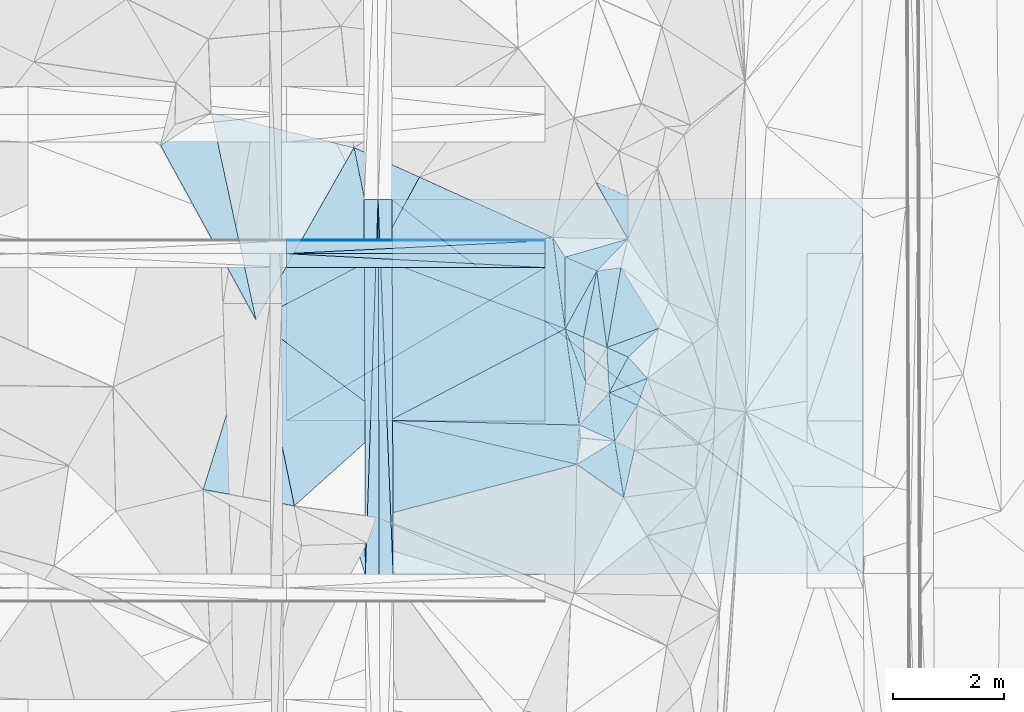
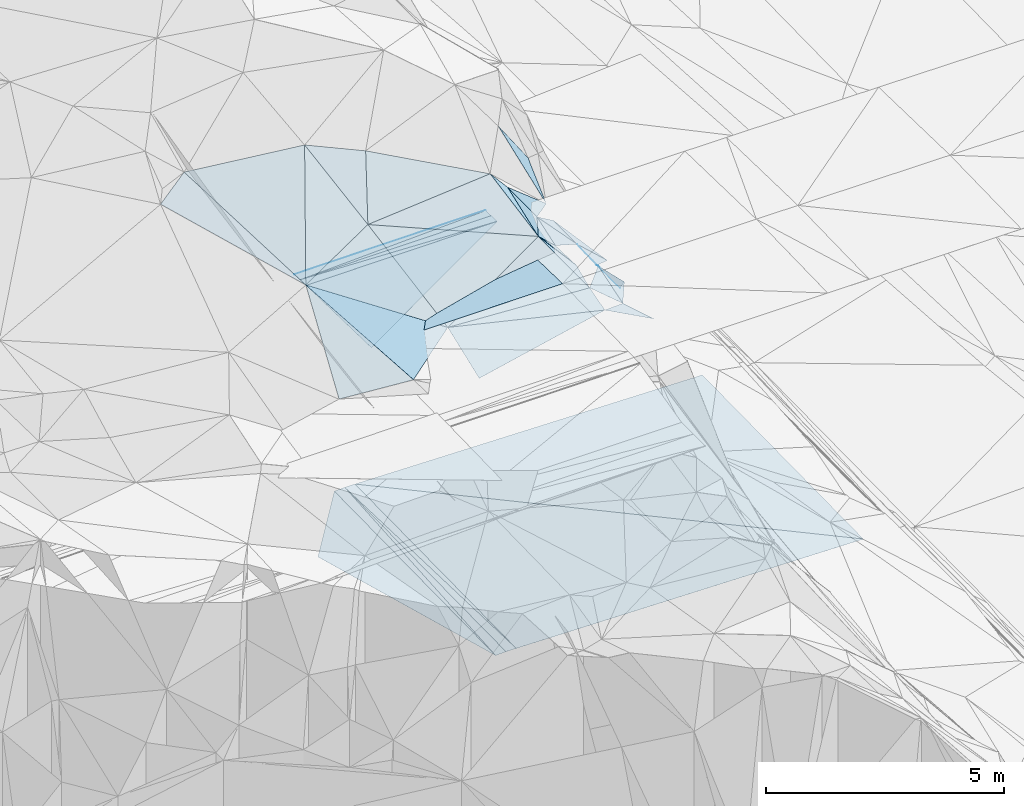
# One storey, part 62 of 275: 46 plates.
"""IFC2X3 building model written with IfcOpenShell, lengths in millimetres."""

import ifcopenshell
import ifcopenshell.guid

model = None  # the IFC model being written
_history = None  # IfcOwnerHistory: only IFC2X3 demands one
_inside = {}  # id of a spatial element -> (the spatial element, [elements in it])
_under = {}  # id of a project, library or spatial element -> (it, [spatial elements below it])
_declared = {}  # id of a project -> (the project, [libraries it declares])
_typed = {}  # id of a type object -> (the type object, [elements of that type])
_made_of = {}  # id of a material, layer set ... -> (it, [elements and type objects made of it])


def new_model(schema):
    """Start an empty IFC model of exactly this schema.

    Asked for "IFC4X3", IfcOpenShell would pick the latest addendum, in which some entities
    have other attributes; the version numbers below select the first issue.
    IFC2X3 requires an IfcOwnerHistory on every rooted entity: one is made here for all.
    """
    global model, _history
    if schema == "IFC4X3":
        model = ifcopenshell.file(schema_version=(4, 3, 0, 0))
    else:
        model = ifcopenshell.file(schema=schema)
    _inside.clear()
    _under.clear()
    _declared.clear()
    _typed.clear()
    _made_of.clear()
    _history = None
    if model.schema == "IFC2X3":
        org = make("IfcOrganization", Name="unknown")
        user = make(
            "IfcPersonAndOrganization",
            ThePerson=make("IfcPerson", FamilyName="unknown"),
            TheOrganization=org,
        )
        app = make(
            "IfcApplication",
            ApplicationDeveloper=org,
            Version="unknown",
            ApplicationFullName="unknown",
            ApplicationIdentifier="unknown",
        )
        _history = make(
            "IfcOwnerHistory",
            OwningUser=user,
            OwningApplication=app,
            ChangeAction="ADDED",
            CreationDate=0,
        )
    return model


def make(cls, **values):
    """One entity of the class cls with the attributes given. An attribute that is None is left unset."""
    return model.create_entity(
        cls, **{name: value for name, value in values.items() if value is not None}
    )


def rooted(cls, **values):
    """An entity with a GlobalId (a new one), such as an element, a storey or a relation."""
    return make(cls, GlobalId=ifcopenshell.guid.new(), OwnerHistory=_history, **values)


def si_unit(unit_type, name, prefix=None):
    """IfcSIUnit, for example si_unit("LENGTHUNIT", "METRE", prefix="MILLI")."""
    return make("IfcSIUnit", UnitType=unit_type, Prefix=prefix, Name=name)


def assignment(units):
    """IfcUnitAssignment: the units of a project."""
    return None if units is None else make("IfcUnitAssignment", Units=units)


def point(xyz):
    """IfcCartesianPoint."""
    return None if xyz is None else make("IfcCartesianPoint", Coordinates=xyz)


def direction(xyz):
    """IfcDirection."""
    return None if xyz is None else make("IfcDirection", DirectionRatios=xyz)


def frame(location, z_axis=None, x_axis=None):
    """IfcAxis2Placement3D, a coordinate frame: its origin and axes. An axis left out is left unset."""
    return make(
        "IfcAxis2Placement3D",
        Location=point(location),
        Axis=direction(z_axis),
        RefDirection=direction(x_axis),
    )


def origin_with_axes():
    """The frame at (0, 0, 0) with the z axis (0, 0, 1) and the x axis (1, 0, 0) written out."""
    return frame((0.0, 0.0, 0.0), z_axis=(0.0, 0.0, 1.0), x_axis=(1.0, 0.0, 0.0))


def place(relative_to, where):
    """IfcLocalPlacement: puts the frame where relative to a parent placement (None: the world)."""
    return make(
        "IfcLocalPlacement", PlacementRelTo=relative_to, RelativePlacement=where
    )


def context(
    kind, dimensions, precision=None, world=None, true_north=None, identifier=None
):
    """IfcGeometricRepresentationContext, for example the 3D "Model" context."""
    return make(
        "IfcGeometricRepresentationContext",
        ContextIdentifier=identifier,
        ContextType=kind,
        CoordinateSpaceDimension=dimensions,
        Precision=precision,
        WorldCoordinateSystem=world,
        TrueNorth=true_north,
    )


def subcontext(parent, identifier, kind, view, scale=None):
    """IfcGeometricRepresentationSubContext, for example "Body" below "Model"."""
    return make(
        "IfcGeometricRepresentationSubContext",
        ContextIdentifier=identifier,
        ContextType=kind,
        ParentContext=parent,
        TargetScale=scale,
        TargetView=view,
    )


def project(units=None, contexts=None):
    """IfcProject with its units and contexts."""
    return rooted(
        "IfcProject",
        Name="project",
        RepresentationContexts=contexts,
        UnitsInContext=assignment(units),
    )


def spatial(cls, under=None, at=None, **own):
    """A site, building, storey or space (cls), placed at a placement, below another one or the project."""
    s = rooted(cls, ObjectPlacement=at, **own)
    if under is not None:
        _under.setdefault(under.id(), (under, []))[1].append(s)
    return s


def polyline(points):
    """IfcPolyline through the points."""
    return make("IfcPolyline", Points=[point(p) for p in points])


def outline(outer, holes=None, kind="AREA"):
    """IfcArbitraryClosedProfileDef: a profile drawn as a closed curve; with holes, ...WithVoids."""
    if holes is None:
        return make("IfcArbitraryClosedProfileDef", ProfileType=kind, OuterCurve=outer)
    return make(
        "IfcArbitraryProfileDefWithVoids",
        ProfileType=kind,
        OuterCurve=outer,
        InnerCurves=holes,
    )


def extrude(swept, where, along, depth):
    """IfcExtrudedAreaSolid: the profile swept, set in the frame where, extruded along a direction by depth."""
    return make(
        "IfcExtrudedAreaSolid",
        SweptArea=swept,
        Position=where,
        ExtrudedDirection=direction(along),
        Depth=depth,
    )


def shape(context_of_items, identifier, shape_type, items):
    """IfcShapeRepresentation: the items that make up one representation, for example the "Body"."""
    return make(
        "IfcShapeRepresentation",
        ContextOfItems=context_of_items,
        RepresentationIdentifier=identifier,
        RepresentationType=shape_type,
        Items=items,
    )


def material(Name=None, Category=None):
    """IfcMaterial."""
    return make("IfcMaterial", Name=Name, Category=Category)


def made_of(thing, what):
    """Note that an element or type object is made of a material, layer set ...; save() writes the relation."""
    if what is not None:
        _made_of.setdefault(what.id(), (what, []))[1].append(thing)
    return thing


def type_object(cls, material=None, **own):
    """A type object (cls), such as IfcWallType, which elements share."""
    return made_of(rooted(cls, **own), material)


def element(
    cls,
    number,
    at=None,
    inside=None,
    cuts=None,
    type_object=None,
    material=None,
    context=None,
    identifier="Body",
    shape_type=None,
    held_by="IfcProductDefinitionShape",
    body=None,
    shapes=None,
    **own,
):
    """One element of the class cls, such as IfcWall. Its Tag is "e" and its number.

    at: its placement. inside: the storey or other place that contains it. cuts: it is an
    opening in that element (IfcRelVoidsElement). A single representation is given by context,
    identifier, shape_type and body (its items); several are given by shapes. held_by: the class
    of the entity that holds the representations. save() writes the other relations.
    """
    e = rooted(cls, Tag="e%d" % number, ObjectPlacement=at, **own)
    if body is not None:
        shapes = [shape(context, identifier, shape_type, body)]
    if shapes is not None:
        e.Representation = make(held_by, Representations=shapes)
    if inside is not None:
        _inside.setdefault(inside.id(), (inside, []))[1].append(e)
    if cuts is not None:
        rooted(
            "IfcRelVoidsElement", RelatingBuildingElement=cuts, RelatedOpeningElement=e
        )
    if type_object is not None:
        _typed.setdefault(type_object.id(), (type_object, []))[1].append(e)
    return made_of(e, material)


def aggregate(whole, parts):
    """IfcRelAggregates: a whole, such as a stair, and the parts it consists of."""
    return rooted("IfcRelAggregates", RelatingObject=whole, RelatedObjects=parts)


def save(model, path):
    """Write the relations noted so far, then the file.

    IfcRelAggregates (storeys below a building ...), IfcRelContainedInSpatialStructure (elements
    in a storey), IfcRelDefinesByType, IfcRelAssociatesMaterial and IfcRelDeclares: one each for
    every whole, place, type object, material and project.
    """
    for whole, parts in _under.values():
        aggregate(whole, parts)
    for where, things in _inside.values():
        rooted(
            "IfcRelContainedInSpatialStructure",
            RelatedElements=things,
            RelatingStructure=where,
        )
    for kind, things in _typed.values():
        rooted("IfcRelDefinesByType", RelatedObjects=things, RelatingType=kind)
    for what, things in _made_of.values():
        rooted("IfcRelAssociatesMaterial", RelatedObjects=things, RelatingMaterial=what)
    for by, libraries in _declared.values():
        rooted("IfcRelDeclares", RelatingContext=by, RelatedDefinitions=libraries)
    model.write(path)


model = new_model("IFC2X3")

# Units and contexts
model_context = context("Model", 3, precision=1e-05, world=origin_with_axes())
body_context = subcontext(model_context, "Body", "Model", "MODEL_VIEW")
ifc_project = project(units=[si_unit("LENGTHUNIT", "METRE", prefix="MILLI"), si_unit("AREAUNIT", "SQUARE_METRE"), si_unit("VOLUMEUNIT", "CUBIC_METRE"), si_unit("MASSUNIT", "GRAM", prefix="KILO"), si_unit("TIMEUNIT", "SECOND"), si_unit("PLANEANGLEUNIT", "RADIAN"), si_unit("SOLIDANGLEUNIT", "STERADIAN"), si_unit("THERMODYNAMICTEMPERATUREUNIT", "DEGREE_CELSIUS"), si_unit("LUMINOUSINTENSITYUNIT", "LUMEN")], contexts=[model_context])

# Site, building, storey
site_placement = place(None, origin_with_axes())
site = spatial("IfcSite", under=ifc_project, at=site_placement, CompositionType="ELEMENT")
building_placement = place(site_placement, origin_with_axes())
building = spatial("IfcBuilding", under=site, at=building_placement, Name="Undefined", CompositionType="ELEMENT")
storey_placement = place(building_placement, origin_with_axes())
storey = spatial("IfcBuildingStorey", under=building, at=storey_placement, Name="Undefined", CompositionType="ELEMENT", Elevation=0.0)

# Plates
ifc_material = material()
plate_type_1 = type_object("IfcPlateType", PredefinedType="NOTDEFINED")
plate_1_placement = place(storey_placement, frame((-105469.201324348, 63292.9219473993, 49162.3171549473), z_axis=(0.00445671719350375, -0.0249921977119847, -0.99967771192789), x_axis=(0.860197157792345, 0.509883731909383, -0.00891233191333803)))
element("IfcPlate", 1, at=plate_1_placement, inside=storey, type_object=plate_type_1, material=ifc_material, Name="00_PR", context=body_context, shape_type="SweptSolid", body=[
    extrude(outline(polyline([(0.0, 0.0), (5392.86474609375, 2.29192664846778e-08), (3989.93603515625, 2366.22436523438), (0.0, 0.0)])), frame((-8.85201319254618e-08, 2.18876761149539e-07, -0.5000001331573), z_axis=(0.0, 0.0, 1.0), x_axis=(1.0, 0.0, 0.0)), (0.0, 0.0, 1.0), 1.0),
])
plate_2_placement = place(storey_placement, frame((-105469.043765166, 66042.921967373, 49093.5671550756), z_axis=(0.00445671719350375, -0.0249921977119847, -0.99967771192789), x_axis=(0.999990054538811, -5.7357974325105e-05, 0.00445954409423353)))
element("IfcPlate", 2, at=plate_2_placement, inside=storey, type_object=plate_type_1, material=ifc_material, Name="00_PR", context=body_context, shape_type="SweptSolid", body=[
    extrude(outline(polyline([(0.0, 0.0), (4638.8154296875, -1.62399373948574e-08), (0.306771844625473, 2750.85913085938), (0.0, 0.0)])), frame((-8.85201319254618e-08, 2.18876761149539e-07, -0.5000001331573), z_axis=(0.0, 0.0, 1.0), x_axis=(1.0, 0.0, 0.0)), (0.0, 0.0, 1.0), 1.0),
])
plate_type_2 = type_object("IfcPlateType", PredefinedType="NOTDEFINED")
plate_3_placement = place(storey_placement, frame((-103826.650499123, 67263.1940728969, 42600.7227228708), z_axis=(0.0498540514075518, 0.0199905378181606, -0.998556434036652), x_axis=(0.00314771709881759, -0.999797850718584, -0.019858236970227)))
element("IfcPlate", 3, at=plate_3_placement, inside=storey, type_object=plate_type_2, material=ifc_material, Name="00_PR", context=body_context, shape_type="SweptSolid", body=[
    extrude(outline(polyline([(0.0, 0.0), (6745.06005859375, -3.5739503800869e-08), (6745.44873046875, 250.311813354492), (0.0, 0.0)])), frame((-8.85201319254618e-08, 2.18876761149539e-07, -0.5000001331573), z_axis=(0.0, 0.0, 1.0), x_axis=(1.0, 0.0, 0.0)), (0.0, 0.0, 1.0), 1.0),
])
plate_4_placement = place(storey_placement, frame((-104076.649661737, 67262.5461842943, 42588.2227234709), z_axis=(0.049876128343471, 0.0199897647867783, -0.998555347051547), x_axis=(0.998748985088213, 0.00258831910303945, 0.0499376149759477)))
element("IfcPlate", 4, at=plate_4_placement, inside=storey, type_object=plate_type_2, material=ifc_material, Name="00_PR", context=body_context, shape_type="SweptSolid", body=[
    extrude(outline(polyline([(0.0, 0.0), (250.312271118164, 1.46246748045087e-09), (-2.93840003013611, 6745.3388671875), (0.0, 0.0)])), frame((-8.85201319254618e-08, 2.18876761149539e-07, -0.5000001331573), z_axis=(0.0, 0.0, 1.0), x_axis=(1.0, 0.0, 0.0)), (0.0, 0.0, 1.0), 1.0),
])
plate_5_placement = place(storey_placement, frame((-103555.455830525, 60520.4247199042, 42461.777200013), z_axis=(-0.0200656186730238, 0.0197911885320088, -0.999602761002469), x_axis=(-0.999793181742788, -0.00370851510160745, 0.0199960160125457)))
element("IfcPlate", 5, at=plate_5_placement, inside=storey, type_object=plate_type_2, material=ifc_material, Name="00_PR", context=body_context, shape_type="SweptSolid", body=[
    extrude(outline(polyline([(0.0, 0.0), (250.0498046875, 2.5465851649642e-10), (248.946228027344, 6745.06005859375), (0.0, 0.0)])), frame((-8.85201319254618e-08, 2.18876761149539e-07, -0.5000001331573), z_axis=(0.0, 0.0, 1.0), x_axis=(1.0, 0.0, 0.0)), (0.0, 0.0, 1.0), 1.0),
])
plate_6_placement = place(storey_placement, frame((-103826.685452077, 67263.1939715177, 42600.7221993988), z_axis=(-0.0200433175559558, 0.0197920939151684, -0.999603190491009), x_axis=(0.999796712713563, 0.00258737511018379, -0.0199959680233973)))
element("IfcPlate", 6, at=plate_6_placement, inside=storey, type_object=plate_type_2, material=ifc_material, Name="00_PR", context=body_context, shape_type="SweptSolid", body=[
    extrude(outline(polyline([(0.0, 0.0), (250.050399780273, 6.83940015733242e-10), (256.506774902344, 6744.77685546875), (0.0, 0.0)])), frame((-8.85201319254618e-08, 2.18876761149539e-07, -0.5000001331573), z_axis=(0.0, 0.0, 1.0), x_axis=(1.0, 0.0, 0.0)), (0.0, 0.0, 1.0), 1.0),
])
for number, where, z_axis, x_axis, name in (
    (7, (-100830.274498399, 66042.6558914657, 49114.2541558087), (0.00445671719350375, -0.0249921977119847, -0.99967771192789), (-0.999990054538875, 5.7357962472799e-05, -0.00445954408009802), "00_PR"),
    (8, (-105469.029439759, 66292.9219611694, 49087.3171556949), (0.00445671719350375, -0.0249921977119847, -0.99967771192789), (0.999990054538811, -5.7357974325105e-05, 0.00445954409423353), "00_PR"),
):
    element("IfcPlate", number, at=place(storey_placement, frame(where, z_axis=z_axis, x_axis=x_axis)), inside=storey, type_object=plate_type_2, material=ifc_material, Name=name, context=body_context, shape_type="SweptSolid", body=[
        extrude(outline(polyline([(0.0, 0.0), (4638.8154296875, -1.62399373948574e-08), (4638.84326171875, 250.078109741211), (0.0, 0.0)])), frame((-8.85201319254618e-08, 2.18876761149539e-07, -0.5000001331573), z_axis=(0.0, 0.0, 1.0), x_axis=(1.0, 0.0, 0.0)), (0.0, 0.0, 1.0), 1.0),
    ])
plate_type_3 = type_object("IfcPlateType", PredefinedType="NOTDEFINED")
plate_7_placement = place(storey_placement, frame((-100830.245854265, 66542.6433940911, 49095.5046256384), z_axis=(0.00445131648355445, -0.0499887354570713, -0.998739862080695), x_axis=(-7.45929924247194e-05, -0.998749770672438, 0.0499888989440421)))
element("IfcPlate", 9, at=plate_7_placement, inside=storey, type_object=plate_type_3, material=ifc_material, Name="00_PR", context=body_context, shape_type="SweptSolid", body=[
    extrude(outline(polyline([(0.0, 0.0), (20.0244464874268, -2.91038304567337e-11), (19.0705547332764, 4638.8154296875), (0.0, 0.0)])), frame((-8.85201319254618e-08, 2.18876761149539e-07, -0.5000001331573), z_axis=(0.0, 0.0, 1.0), x_axis=(1.0, 0.0, 0.0)), (0.0, 0.0, 1.0), 1.0),
])
plate_8_placement = place(storey_placement, frame((-105469.0166185, 66522.9100808625, 49075.8176243944), z_axis=(0.00445111480713597, -0.0499389231699433, -0.998742354929238), x_axis=(7.46349675932083e-05, 0.998752262639191, -0.0499390859219244)))
element("IfcPlate", 10, at=plate_8_placement, inside=storey, type_object=plate_type_3, material=ifc_material, Name="00_PR", context=body_context, shape_type="SweptSolid", body=[
    extrude(outline(polyline([(0.0, 0.0), (20.0243949890137, 1.30967237055302e-10), (19.0717754364014, 4638.8154296875), (0.0, 0.0)])), frame((-8.85201319254618e-08, 2.18876761149539e-07, -0.5000001331573), z_axis=(0.0, 0.0, 1.0), x_axis=(1.0, 0.0, 0.0)), (0.0, 0.0, 1.0), 1.0),
])
plate_type_4 = type_object("IfcPlateType", PredefinedType="NOTDEFINED")
plate_9_placement = place(storey_placement, frame((-106016.675215743, 65102.2080277684, 49869.5147014846), z_axis=(0.00436078686112087, 0.240791988652599, -0.970566948612345), x_axis=(-0.468948656068637, 0.857727687735567, 0.210690226786193)))
element("IfcPlate", 11, at=plate_9_placement, inside=storey, type_object=plate_type_4, material=ifc_material, Name="00", context=body_context, shape_type="SweptSolid", body=[
    extrude(outline(polyline([(0.0, 0.0), (3654.65454101563, 4.97675500810146e-09), (3764.02197265625, 1088.27331542969), (0.0, 0.0)])), frame((-8.85201319254618e-08, 2.18876761149539e-07, -0.5000001331573), z_axis=(0.0, 0.0, 1.0), x_axis=(1.0, 0.0, 0.0)), (0.0, 0.0, 1.0), 1.0),
])
plate_type_5 = type_object("IfcPlateType", PredefinedType="NOTDEFINED")
plate_10_placement = place(storey_placement, frame((-100830.24734789, 66522.6440090119, 49096.5056244012), z_axis=(0.00445111678322818, -0.0499329100893918, -0.998742655567182), x_axis=(-5.57119462018614e-05, -0.998752560311599, 0.0499331569921673)))
element("IfcPlate", 12, at=plate_10_placement, inside=storey, type_object=plate_type_5, material=ifc_material, Name="00_PR", context=body_context, shape_type="SweptSolid", body=[
    extrude(outline(polyline([(0.0, 0.0), (230.287857055664, 7.71251507103443e-10), (229.247589111328, 4638.8154296875), (0.0, 0.0)])), frame((-8.85201319254618e-08, 2.18876761149539e-07, -0.5000001331573), z_axis=(0.0, 0.0, 1.0), x_axis=(1.0, 0.0, 0.0)), (0.0, 0.0, 1.0), 1.0),
])
plate_11_placement = place(storey_placement, frame((-105469.029446194, 66292.9094898988, 49087.3176237522), z_axis=(0.00445133086710392, -0.0499372419707403, -0.998742438027877), x_axis=(5.57099558727869e-05, 0.998752343723243, -0.049937488961006)))
element("IfcPlate", 13, at=plate_11_placement, inside=storey, type_object=plate_type_5, material=ifc_material, Name="00_PR", context=body_context, shape_type="SweptSolid", body=[
    extrude(outline(polyline([(0.0, 0.0), (230.28791809082, 9.89530235528946e-10), (229.247482299805, 4638.8154296875), (0.0, 0.0)])), frame((-8.85201319254618e-08, 2.18876761149539e-07, -0.5000001331573), z_axis=(0.0, 0.0, 1.0), x_axis=(1.0, 0.0, 0.0)), (0.0, 0.0, 1.0), 1.0),
])
plate_type_6 = type_object("IfcPlateType", PredefinedType="NOTDEFINED")
plate_12_placement = place(storey_placement, frame((-105551.565501963, 65398.0618447015, 42551.3640996621), z_axis=(-0.0001170259226823, 0.0198571444894536, -0.999802820618975), x_axis=(0.620328597982233, 0.784188824147713, 0.0155022129783304)))
element("IfcPlate", 14, at=plate_12_placement, inside=storey, type_object=plate_type_6, material=ifc_material, Name="00_PR", context=body_context, shape_type="SweptSolid", body=[
    extrude(outline(polyline([(0.0, 0.0), (2377.59619140625, 1.44063960760832e-09), (-2899.85986328125, 4200.9599609375), (0.0, 0.0)])), frame((-8.85201319254618e-08, 2.18876761149539e-07, -0.5000001331573), z_axis=(0.0, 0.0, 1.0), x_axis=(1.0, 0.0, 0.0)), (0.0, 0.0, 1.0), 1.0),
])
plate_type_7 = type_object("IfcPlateType", PredefinedType="NOTDEFINED")
plate_13_placement = place(storey_placement, frame((-103576.685878312, 67263.8409619394, 42595.7221990522), z_axis=(-0.0200455022387264, 0.0198206835130344, -0.999602580201289), x_axis=(0.99979662068917, 0.00260989112805105, -0.0199976430315116)))
element("IfcPlate", 15, at=plate_13_placement, inside=storey, type_object=plate_type_7, material=ifc_material, Name="00_PR", context=body_context, shape_type="SweptSolid", body=[
    extrude(outline(polyline([(0.0, 0.0), (8442.9951171875, -4.58239810541272e-08), (8449.439453125, 6735.3330078125), (0.0, 0.0)])), frame((-8.85201319254618e-08, 2.18876761149539e-07, -0.5000001331573), z_axis=(0.0, 0.0, 1.0), x_axis=(1.0, 0.0, 0.0)), (0.0, 0.0, 1.0), 1.0),
])
plate_type_8 = type_object("IfcPlateType", PredefinedType="NOTDEFINED")
plate_14_placement = place(storey_placement, frame((-95114.0626632694, 60551.9062880618, 42292.9291988022), z_axis=(-0.0200682510399799, 0.0197920061024449, -0.999602691970483), x_axis=(-0.999793062227786, -0.0037286561281597, 0.0199982460397029)))
element("IfcPlate", 16, at=plate_14_placement, inside=storey, type_object=plate_type_8, material=ifc_material, Name="00_PR", context=body_context, shape_type="SweptSolid", body=[
    extrude(outline(polyline([(0.0, 0.0), (8443.140625, -1.06010702438653e-08), (8441.900390625, 6744.77978515625), (0.0, 0.0)])), frame((-8.85201319254618e-08, 2.18876761149539e-07, -0.5000001331573), z_axis=(0.0, 0.0, 1.0), x_axis=(1.0, 0.0, 0.0)), (0.0, 0.0, 1.0), 1.0),
])
plate_type_9 = type_object("IfcPlateType", PredefinedType="NOTDEFINED")
plate_15_placement = place(storey_placement, frame((-99344.3383490739, 66554.3521445999, 48739.6977704147), z_axis=(-0.667161054418936, 0.43536352660778, -0.604445801678074), x_axis=(-0.674842191825124, -0.696818584113825, 0.242964764865747)))
element("IfcPlate", 17, at=plate_15_placement, inside=storey, type_object=plate_type_9, material=ifc_material, Name="00", context=body_context, shape_type="SweptSolid", body=[
    extrude(outline(polyline([(0.0, 0.0), (823.164611816406, -5.03496266901493e-09), (1229.8876953125, 937.377380371094), (0.0, 0.0)])), frame((-8.85201319254618e-08, 2.18876761149539e-07, -0.5000001331573), z_axis=(0.0, 0.0, 1.0), x_axis=(1.0, 0.0, 0.0)), (0.0, 0.0, 1.0), 1.0),
])
plate_16_placement = place(storey_placement, frame((-99337.4004899939, 64436.0968160308, 48439.708562326), z_axis=(-0.81242426670054, -0.015402839233467, -0.58286324589876), x_axis=(0.493809782029726, -0.549714109644213, -0.673770210702302)))
element("IfcPlate", 18, at=plate_16_placement, inside=storey, type_object=plate_type_9, material=ifc_material, Name="00", context=body_context, shape_type="SweptSolid", body=[
    extrude(outline(polyline([(0.0, 0.0), (697.567199707031, -1.7134880181402e-09), (-144.788925170898, 864.023254394531), (0.0, 0.0)])), frame((-8.85201319254618e-08, 2.18876761149539e-07, -0.5000001331573), z_axis=(0.0, 0.0, 1.0), x_axis=(1.0, 0.0, 0.0)), (0.0, 0.0, 1.0), 1.0),
])
plate_type_10 = type_object("IfcPlateType", PredefinedType="NOTDEFINED")
plate_17_placement = place(storey_placement, frame((-99899.8099164169, 65980.5749065463, 48939.60087206), z_axis=(-0.597834700724208, 0.0736721962875272, -0.798226833740991), x_axis=(-0.197550996818109, -0.978596734991133, 0.0576370880671894)))
element("IfcPlate", 19, at=plate_17_placement, inside=storey, type_object=plate_type_10, material=ifc_material, Name="00", context=body_context, shape_type="SweptSolid", body=[
    extrude(outline(polyline([(0.0, 0.0), (1214.49572753906, -5.32600097358227e-09), (1147.71911621094, 440.046447753906), (0.0, 0.0)])), frame((-8.85201319254618e-08, 2.18876761149539e-07, -0.5000001331573), z_axis=(0.0, 0.0, 1.0), x_axis=(1.0, 0.0, 0.0)), (0.0, 0.0, 1.0), 1.0),
])
plate_type_11 = type_object("IfcPlateType", PredefinedType="NOTDEFINED")
plate_18_placement = place(storey_placement, frame((-104258.098095689, 68197.7040923462, 50969.5544207564), z_axis=(0.0225181360643391, 0.453194464835168, -0.891127213472327), x_axis=(0.89603738554861, -0.404481460051194, -0.183062153855092)))
element("IfcPlate", 20, at=plate_18_placement, inside=storey, type_object=plate_type_11, material=ifc_material, Name="00", context=body_context, shape_type="SweptSolid", body=[
    extrude(outline(polyline([(0.0, 0.0), (1311.03015136719, -6.25732354819775e-10), (1334.37060546875, 1796.12231445313), (0.0, 0.0)])), frame((-8.85201319254618e-08, 2.18876761149539e-07, -0.5000001331573), z_axis=(0.0, 0.0, 1.0), x_axis=(1.0, 0.0, 0.0)), (0.0, 0.0, 1.0), 1.0),
])
plate_type_12 = type_object("IfcPlateType", PredefinedType="NOTDEFINED")
plate_19_placement = place(storey_placement, frame((-98992.8812806945, 64052.4552113826, 47969.6985796792), z_axis=(-0.705025270959756, -0.373545399664739, -0.602829330488683), x_axis=(-0.247565596902683, -0.666924278962632, 0.702796756794161)))
element("IfcPlate", 21, at=plate_19_placement, inside=storey, type_object=plate_type_12, material=ifc_material, Name="00", context=body_context, shape_type="SweptSolid", body=[
    extrude(outline(polyline([(0.0, 0.0), (725.672119140625, 1.93540472537279e-09), (1016.43701171875, 650.350463867188), (0.0, 0.0)])), frame((-8.85201319254618e-08, 2.18876761149539e-07, -0.5000001331573), z_axis=(0.0, 0.0, 1.0), x_axis=(1.0, 0.0, 0.0)), (0.0, 0.0, 1.0), 1.0),
])
plate_type_13 = type_object("IfcPlateType", PredefinedType="NOTDEFINED")
plate_20_placement = place(storey_placement, frame((-99718.8454741306, 64606.4225627199, 49009.7206956734), z_axis=(-0.8293519245828, 0.0120647927929476, -0.558596299634779), x_axis=(0.539756650334233, -0.24100220291263, -0.806585827182221)))
element("IfcPlate", 22, at=plate_20_placement, inside=storey, type_object=plate_type_13, material=ifc_material, Name="00", context=body_context, shape_type="SweptSolid", body=[
    extrude(outline(polyline([(0.0, 0.0), (706.682373046875, 1.25146470963955e-09), (283.012573242188, 766.814086914063), (0.0, 0.0)])), frame((-8.85201319254618e-08, 2.18876761149539e-07, -0.5000001331573), z_axis=(0.0, 0.0, 1.0), x_axis=(1.0, 0.0, 0.0)), (0.0, 0.0, 1.0), 1.0),
])
plate_type_14 = type_object("IfcPlateType", PredefinedType="NOTDEFINED")
plate_21_placement = place(storey_placement, frame((-99344.3146541775, 66554.4013893215, 48739.7123856276), z_axis=(-0.61977659762609, 0.533857033360447, -0.575216165425322), x_axis=(-0.292534690230484, 0.522979114872492, 0.800572482926399)))
element("IfcPlate", 23, at=plate_21_placement, inside=storey, type_object=plate_type_14, material=ifc_material, Name="00", context=body_context, shape_type="SweptSolid", body=[
    extrude(outline(polyline([(0.0, 0.0), (1961.0966796875, -7.69796315580606e-09), (968.641723632813, 389.7861328125), (0.0, 0.0)])), frame((-8.85201319254618e-08, 2.18876761149539e-07, -0.5000001331573), z_axis=(0.0, 0.0, 1.0), x_axis=(1.0, 0.0, 0.0)), (0.0, 0.0, 1.0), 1.0),
])
plate_type_15 = type_object("IfcPlateType", PredefinedType="NOTDEFINED")
plate_22_placement = place(storey_placement, frame((-99416.2138959004, 61919.1129206473, 48619.5359399553), z_axis=(-0.315542714994322, -0.197677776850364, -0.928092824858327), x_axis=(-0.808496435711238, 0.568022487592778, 0.153895961711594)))
element("IfcPlate", 24, at=plate_22_placement, inside=storey, type_object=plate_type_15, material=ifc_material, Name="00", context=body_context, shape_type="SweptSolid", body=[
    extrude(outline(polyline([(0.0, 0.0), (1039.66345214844, -1.09957909444347e-09), (680.797241210938, 780.906555175781), (0.0, 0.0)])), frame((-8.85201319254618e-08, 2.18876761149539e-07, -0.5000001331573), z_axis=(0.0, 0.0, 1.0), x_axis=(1.0, 0.0, 0.0)), (0.0, 0.0, 1.0), 1.0),
])
plate_type_16 = type_object("IfcPlateType", PredefinedType="NOTDEFINED")
plate_23_placement = place(storey_placement, frame((-100256.635366541, 62509.8552804315, 48779.5086398158), z_axis=(-0.0301771695448627, 0.182679205528357, -0.982709339685845), x_axis=(-0.970820654043145, 0.228643269790012, 0.072315370862434)))
element("IfcPlate", 25, at=plate_23_placement, inside=storey, type_object=plate_type_16, material=ifc_material, Name="00", context=body_context, shape_type="SweptSolid", body=[
    extrude(outline(polyline([(0.0, 0.0), (3457.07958984375, -9.42964106798172e-09), (133.899139404297, 705.883178710938), (0.0, 0.0)])), frame((-8.85201319254618e-08, 2.18876761149539e-07, -0.5000001331573), z_axis=(0.0, 0.0, 1.0), x_axis=(1.0, 0.0, 0.0)), (0.0, 0.0, 1.0), 1.0),
])
plate_type_17 = type_object("IfcPlateType", PredefinedType="NOTDEFINED")
plate_24_placement = place(storey_placement, frame((-99718.4426999578, 64606.3895353834, 49009.5008649255), z_axis=(-0.0238039203414638, -0.0539897364563632, -0.998257723102481), x_axis=(-0.915012165239938, 0.403426247860648, -1.08923821521263e-10)))
element("IfcPlate", 26, at=plate_24_placement, inside=storey, type_object=plate_type_17, material=ifc_material, Name="00", context=body_context, shape_type="SweptSolid", body=[
    extrude(outline(polyline([(0.0, 0.0), (460.108673095703, 2.37560016103089e-09), (720.047241210938, 1186.35241699219), (0.0, 0.0)])), frame((-8.85201319254618e-08, 2.18876761149539e-07, -0.5000001331573), z_axis=(0.0, 0.0, 1.0), x_axis=(1.0, 0.0, 0.0)), (0.0, 0.0, 1.0), 1.0),
])
plate_type_18 = type_object("IfcPlateType", PredefinedType="NOTDEFINED")
plate_25_placement = place(storey_placement, frame((-100468.424980021, 64941.9363017066, 49269.6082140988), z_axis=(-0.621308000668644, -0.00323570793324796, -0.783559760643247), x_axis=(0.738463517071979, -0.336793463775766, -0.584159050868516)))
element("IfcPlate", 27, at=plate_25_placement, inside=storey, type_object=plate_type_18, material=ifc_material, Name="00", context=body_context, shape_type="SweptSolid", body=[
    extrude(outline(polyline([(0.0, 0.0), (445.084259033203, -2.99769453704357e-09), (767.270446777344, 747.526611328125), (0.0, 0.0)])), frame((-8.85201319254618e-08, 2.18876761149539e-07, -0.5000001331573), z_axis=(0.0, 0.0, 1.0), x_axis=(1.0, 0.0, 0.0)), (0.0, 0.0, 1.0), 1.0),
])
plate_type_19 = type_object("IfcPlateType", PredefinedType="NOTDEFINED")
plate_26_placement = place(storey_placement, frame((-100690.461500032, 66582.3264255795, 49959.5560284753), z_axis=(-0.320293558360523, 0.330141705319426, -0.88792932763905), x_axis=(0.474998882302587, -0.754996805975197, -0.452057391023026)))
element("IfcPlate", 28, at=plate_26_placement, inside=storey, type_object=plate_type_19, material=ifc_material, Name="00", context=body_context, shape_type="SweptSolid", body=[
    extrude(outline(polyline([(0.0, 0.0), (464.542785644531, 8.73114913702011e-10), (1655.82165527344, 688.516296386719), (0.0, 0.0)])), frame((-8.85201319254618e-08, 2.18876761149539e-07, -0.5000001331573), z_axis=(0.0, 0.0, 1.0), x_axis=(1.0, 0.0, 0.0)), (0.0, 0.0, 1.0), 1.0),
])
plate_type_20 = type_object("IfcPlateType", PredefinedType="NOTDEFINED")
plate_27_placement = place(storey_placement, frame((-99578.9292446437, 62929.6923659633, 48459.6830890852), z_axis=(-0.741659494936827, -0.219605213063142, -0.633809706430521), x_axis=(0.66944334731846, -0.301873334900511, -0.678762178091192)))
element("IfcPlate", 29, at=plate_27_placement, inside=storey, type_object=plate_type_20, material=ifc_material, Name="00", context=body_context, shape_type="SweptSolid", body=[
    extrude(outline(polyline([(0.0, 0.0), (530.377197265625, -3.38695826940238e-09), (305.254425048828, 990.009948730469), (0.0, 0.0)])), frame((-8.85201319254618e-08, 2.18876761149539e-07, -0.5000001331573), z_axis=(0.0, 0.0, 1.0), x_axis=(1.0, 0.0, 0.0)), (0.0, 0.0, 1.0), 1.0),
])
plate_type_21 = type_object("IfcPlateType", PredefinedType="NOTDEFINED")
plate_28_placement = place(storey_placement, frame((-100690.331097585, 66582.4049169768, 49959.5643410602), z_axis=(-0.0594888675417823, 0.48712362716236, -0.87130456586591), x_axis=(-0.993894514461854, -0.11015597118287, 0.00627344685116043)))
element("IfcPlate", 30, at=plate_28_placement, inside=storey, type_object=plate_type_21, material=ifc_material, Name="00", context=body_context, shape_type="SweptSolid", body=[
    extrude(outline(polyline([(0.0, 0.0), (3188.0400390625, 1.1306838132441e-08), (2263.77319335938, 1540.23718261719), (0.0, 0.0)])), frame((-8.85201319254618e-08, 2.18876761149539e-07, -0.5000001331573), z_axis=(0.0, 0.0, 1.0), x_axis=(1.0, 0.0, 0.0)), (0.0, 0.0, 1.0), 1.0),
])
plate_type_22 = type_object("IfcPlateType", PredefinedType="NOTDEFINED")
plate_29_placement = place(storey_placement, frame((-99467.2071793809, 66040.5849781786, 48659.6461683792), z_axis=(-0.704859029576041, -0.0490530969710593, -0.707649307286222), x_axis=(0.478887285248385, -0.768858053891902, -0.423703033967175)))
element("IfcPlate", 31, at=plate_29_placement, inside=storey, type_object=plate_type_22, material=ifc_material, Name="00", context=body_context, shape_type="SweptSolid", body=[
    extrude(outline(polyline([(0.0, 0.0), (1416.08618164063, 3.22324922308326e-09), (833.918212890625, 1243.89733886719), (0.0, 0.0)])), frame((-8.85201319254618e-08, 2.18876761149539e-07, -0.5000001331573), z_axis=(0.0, 0.0, 1.0), x_axis=(1.0, 0.0, 0.0)), (0.0, 0.0, 1.0), 1.0),
])
plate_type_23 = type_object("IfcPlateType", PredefinedType="NOTDEFINED")
plate_30_placement = place(storey_placement, frame((-99718.695197979, 64606.3602589797, 49009.579367778), z_axis=(-0.528802616635431, -0.112539698083403, -0.841250621987775), x_axis=(-0.130483042157907, 0.990166607541205, -0.0504407079605334)))
element("IfcPlate", 32, at=plate_30_placement, inside=storey, type_object=plate_type_23, material=ifc_material, Name="00", context=body_context, shape_type="SweptSolid", body=[
    extrude(outline(polyline([(0.0, 0.0), (1387.76794433594, -1.92085281014442e-09), (1404.91784667969, 518.561340332031), (0.0, 0.0)])), frame((-8.85201319254618e-08, 2.18876761149539e-07, -0.5000001331573), z_axis=(0.0, 0.0, 1.0), x_axis=(1.0, 0.0, 0.0)), (0.0, 0.0, 1.0), 1.0),
])
plate_type_24 = type_object("IfcPlateType", PredefinedType="NOTDEFINED")
plate_31_placement = place(storey_placement, frame((-100468.138400253, 64942.128801872, 49269.5384911907), z_axis=(-0.048137906553082, 0.381763924753092, -0.923005442947008), x_axis=(-0.917327377987579, 0.348733733726272, 0.19208140085851)))
element("IfcPlate", 33, at=plate_31_placement, inside=storey, type_object=plate_type_24, material=ifc_material, Name="00", context=body_context, shape_type="SweptSolid", body=[
    extrude(outline(polyline([(0.0, 0.0), (3696.349609375, 4.0381564758718e-09), (908.355651855469, 1546.18566894531), (0.0, 0.0)])), frame((-8.85201319254618e-08, 2.18876761149539e-07, -0.5000001331573), z_axis=(0.0, 0.0, 1.0), x_axis=(1.0, 0.0, 0.0)), (0.0, 0.0, 1.0), 1.0),
])
plate_type_25 = type_object("IfcPlateType", PredefinedType="NOTDEFINED")
plate_32_placement = place(storey_placement, frame((-104258.195121111, 68197.6849745608, 50969.5532412251), z_axis=(-0.171560553376697, 0.414990002770398, -0.893504490266113), x_axis=(0.178424422274763, -0.878864682957872, -0.442449539027081)))
element("IfcPlate", 34, at=plate_32_placement, inside=storey, type_object=plate_type_25, material=ifc_material, Name="00", context=body_context, shape_type="SweptSolid", body=[
    extrude(outline(polyline([(0.0, 0.0), (2237.54321289063, -8.71659722179174e-09), (2893.35180664063, 2347.87451171875), (0.0, 0.0)])), frame((-8.85201319254618e-08, 2.18876761149539e-07, -0.5000001331573), z_axis=(0.0, 0.0, 1.0), x_axis=(1.0, 0.0, 0.0)), (0.0, 0.0, 1.0), 1.0),
])
plate_type_26 = type_object("IfcPlateType", PredefinedType="NOTDEFINED")
plate_33_placement = place(storey_placement, frame((-100468.495661183, 64942.0503413229, 49269.6967646954), z_axis=(-0.762662722498593, 0.224842445001792, -0.606458116143769), x_axis=(-0.00111176726465928, 0.937176638912904, 0.348853424018542)))
element("IfcPlate", 35, at=plate_33_placement, inside=storey, type_object=plate_type_26, material=ifc_material, Name="00", context=body_context, shape_type="SweptSolid", body=[
    extrude(outline(polyline([(0.0, 0.0), (1375.93603515625, -4.65661287307739e-10), (857.598022460938, 880.582580566406), (0.0, 0.0)])), frame((-8.85201319254618e-08, 2.18876761149539e-07, -0.5000001331573), z_axis=(0.0, 0.0, 1.0), x_axis=(1.0, 0.0, 0.0)), (0.0, 0.0, 1.0), 1.0),
])
plate_type_27 = type_object("IfcPlateType", PredefinedType="NOTDEFINED")
plate_34_placement = place(storey_placement, frame((-99337.359679356, 64436.275230655, 48439.7044637308), z_axis=(-0.730804286413555, 0.341427021247241, -0.591060643353802), x_axis=(-0.539756650332021, 0.2410022029086, 0.806585827184906)))
element("IfcPlate", 36, at=plate_34_placement, inside=storey, type_object=plate_type_27, material=ifc_material, Name="00", context=body_context, shape_type="SweptSolid", body=[
    extrude(outline(polyline([(0.0, 0.0), (706.682373046875, 1.25146470963955e-09), (-478.149749755859, 694.530639648438), (0.0, 0.0)])), frame((-8.85201319254618e-08, 2.18876761149539e-07, -0.5000001331573), z_axis=(0.0, 0.0, 1.0), x_axis=(1.0, 0.0, 0.0)), (0.0, 0.0, 1.0), 1.0),
])
plate_type_28 = type_object("IfcPlateType", PredefinedType="NOTDEFINED")
plate_35_placement = place(storey_placement, frame((-100468.292431518, 64942.0084857932, 49269.5381509817), z_axis=(-0.356209374600333, 0.141132697585731, -0.9236863337297), x_axis=(0.3460965351773, -0.898291393779338, -0.27072081597144)))
element("IfcPlate", 37, at=plate_35_placement, inside=storey, type_object=plate_type_28, material=ifc_material, Name="00", context=body_context, shape_type="SweptSolid", body=[
    extrude(outline(polyline([(0.0, 0.0), (1071.21423339844, 6.06814865022898e-09), (1734.76037597656, 404.359527587891), (0.0, 0.0)])), frame((-8.85201319254618e-08, 2.18876761149539e-07, -0.5000001331573), z_axis=(0.0, 0.0, 1.0), x_axis=(1.0, 0.0, 0.0)), (0.0, 0.0, 1.0), 1.0),
])
plate_type_29 = type_object("IfcPlateType", PredefinedType="NOTDEFINED")
plate_36_placement = place(storey_placement, frame((-100218.697264533, 63215.4563617374, 48909.5103121427), z_axis=(-0.0296278719083171, 0.199921549946053, -0.979363856323763), x_axis=(-0.999063886037555, 0.0249742387872295, 0.0353219338731406)))
element("IfcPlate", 38, at=plate_36_placement, inside=storey, type_object=plate_type_29, material=ifc_material, Name="00", context=body_context, shape_type="SweptSolid", body=[
    extrude(outline(polyline([(0.0, 0.0), (3397.32250976563, -9.15315467864275e-09), (305.034332275391, 1754.95129394531), (0.0, 0.0)])), frame((-8.85201319254618e-08, 2.18876761149539e-07, -0.5000001331573), z_axis=(0.0, 0.0, 1.0), x_axis=(1.0, 0.0, 0.0)), (0.0, 0.0, 1.0), 1.0),
])
plate_type_30 = type_object("IfcPlateType", PredefinedType="NOTDEFINED")
plate_37_placement = place(storey_placement, frame((-99676.6291840254, 63794.2350770141, 48929.6148587119), z_axis=(-0.526890704736651, 0.359262105446876, -0.770270682845968), x_axis=(0.707737729196709, -0.316374031844013, -0.631676165963422)))
element("IfcPlate", 39, at=plate_37_placement, inside=storey, type_object=plate_type_30, material=ifc_material, Name="00", context=body_context, shape_type="SweptSolid", body=[
    extrude(outline(polyline([(0.0, 0.0), (712.390319824219, 1.26965460367501e-09), (639.537048339844, 753.918029785156), (0.0, 0.0)])), frame((-8.85201319254618e-08, 2.18876761149539e-07, -0.5000001331573), z_axis=(0.0, 0.0, 1.0), x_axis=(1.0, 0.0, 0.0)), (0.0, 0.0, 1.0), 1.0),
])
plate_type_31 = type_object("IfcPlateType", PredefinedType="NOTDEFINED")
plate_38_placement = place(storey_placement, frame((-99578.7580898564, 62930.0035227015, 48459.5881852242), z_axis=(-0.399349665686036, 0.402707348662808, -0.823618015738742), x_axis=(-0.768505511033869, 0.342824186764463, 0.540250734825836)))
element("IfcPlate", 40, at=plate_38_placement, inside=storey, type_object=plate_type_31, material=ifc_material, Name="00", context=body_context, shape_type="SweptSolid", body=[
    extrude(outline(polyline([(0.0, 0.0), (832.946594238281, 3.35057848133147e-09), (625.370239257813, 765.710144042969), (0.0, 0.0)])), frame((-8.85201319254618e-08, 2.18876761149539e-07, -0.5000001331573), z_axis=(0.0, 0.0, 1.0), x_axis=(1.0, 0.0, 0.0)), (0.0, 0.0, 1.0), 1.0),
])
plate_type_32 = type_object("IfcPlateType", PredefinedType="NOTDEFINED")
plate_39_placement = place(storey_placement, frame((-106016.793206514, 65102.1575065296, 49869.518639333), z_axis=(-0.231632233546825, 0.139778937374231, -0.962708864116582), x_axis=(0.770604171404235, -0.577631312015244, -0.269279182994044)))
element("IfcPlate", 41, at=plate_39_placement, inside=storey, type_object=plate_type_32, material=ifc_material, Name="00", context=body_context, shape_type="SweptSolid", body=[
    extrude(outline(polyline([(0.0, 0.0), (3119.43896484375, 2.33376340474933e-09), (2632.58862304688, 2258.15771484375), (0.0, 0.0)])), frame((-8.85201319254618e-08, 2.18876761149539e-07, -0.5000001331573), z_axis=(0.0, 0.0, 1.0), x_axis=(1.0, 0.0, 0.0)), (0.0, 0.0, 1.0), 1.0),
])
plate_type_33 = type_object("IfcPlateType", PredefinedType="NOTDEFINED")
plate_40_placement = place(storey_placement, frame((-103858.930841789, 66231.1288797218, 49979.5258176939), z_axis=(-0.107746849600328, 0.29835888236992, -0.948352568253061), x_axis=(0.0796102422178191, -0.948253301737416, -0.307372550950974)))
element("IfcPlate", 42, at=plate_40_placement, inside=storey, type_object=plate_type_33, material=ifc_material, Name="00", context=body_context, shape_type="SweptSolid", body=[
    extrude(outline(polyline([(0.0, 0.0), (3090.7119140625, 5.16592990607023e-09), (932.503601074219, 2252.34033203125), (0.0, 0.0)])), frame((-8.85201319254618e-08, 2.18876761149539e-07, -0.5000001331573), z_axis=(0.0, 0.0, 1.0), x_axis=(1.0, 0.0, 0.0)), (0.0, 0.0, 1.0), 1.0),
])
plate_type_34 = type_object("IfcPlateType", PredefinedType="NOTDEFINED")
plate_41_placement = place(storey_placement, frame((-103612.866920281, 63300.3523530399, 49029.5250306107), z_axis=(-0.0845481145616602, 0.300816795165842, -0.949926771951512), x_axis=(-0.0796102422275672, 0.94825330173579, 0.307372550953465)))
element("IfcPlate", 43, at=plate_41_placement, inside=storey, type_object=plate_type_34, material=ifc_material, Name="00", context=body_context, shape_type="SweptSolid", body=[
    extrude(outline(polyline([(0.0, 0.0), (3090.7119140625, 5.16592990607023e-09), (1380.19982910156, 3276.7587890625), (0.0, 0.0)])), frame((-8.85201319254618e-08, 2.18876761149539e-07, -0.5000001331573), z_axis=(0.0, 0.0, 1.0), x_axis=(1.0, 0.0, 0.0)), (0.0, 0.0, 1.0), 1.0),
])
plate_type_35 = type_object("IfcPlateType", PredefinedType="NOTDEFINED")
plate_42_placement = place(storey_placement, frame((-103851.816006732, 61565.4932494772, 48859.5033285476), z_axis=(-0.0494617257854614, 0.104156061407099, -0.993330283719612), x_axis=(0.135824735730466, 0.986009739544781, 0.0966252280027469)))
element("IfcPlate", 44, at=plate_42_placement, inside=storey, type_object=plate_type_35, material=ifc_material, Name="00", context=body_context, shape_type="SweptSolid", body=[
    extrude(outline(polyline([(0.0, 0.0), (1759.37487792969, -7.23230186849833e-09), (1411.69458007813, 3439.55200195313), (0.0, 0.0)])), frame((-8.85201319254618e-08, 2.18876761149539e-07, -0.5000001331573), z_axis=(0.0, 0.0, 1.0), x_axis=(1.0, 0.0, 0.0)), (0.0, 0.0, 1.0), 1.0),
])
plate_type_36 = type_object("IfcPlateType", PredefinedType="NOTDEFINED")
plate_43_placement = place(storey_placement, frame((-105328.681970348, 61765.4231513981, 49219.5134825901), z_axis=(0.0968126549689763, 0.209500435852314, -0.973004047892684), x_axis=(-0.982649245610751, 0.175506215755226, -0.0599835671822052)))
element("IfcPlate", 45, at=plate_43_placement, inside=storey, type_object=plate_type_36, material=ifc_material, Name="00", context=body_context, shape_type="SweptSolid", body=[
    extrude(outline(polyline([(0.0, 0.0), (1667.12329101563, 3.31783667206764e-09), (1222.64501953125, 3245.75708007813), (0.0, 0.0)])), frame((-8.85201319254618e-08, 2.18876761149539e-07, -0.5000001331573), z_axis=(0.0, 0.0, 1.0), x_axis=(1.0, 0.0, 0.0)), (0.0, 0.0, 1.0), 1.0),
])
plate_type_37 = type_object("IfcPlateType", PredefinedType="NOTDEFINED")
plate_44_placement = place(storey_placement, frame((-106016.611467965, 65102.2199124793, 49869.5223296086), z_axis=(0.131882148269039, 0.264559917437256, -0.955308928595109), x_axis=(-0.205185158181588, 0.950140456807154, 0.234802391811263)))
element("IfcPlate", 46, at=plate_44_placement, inside=storey, type_object=plate_type_37, material=ifc_material, Name="00", context=body_context, shape_type="SweptSolid", body=[
    extrude(outline(polyline([(0.0, 0.0), (3918.1884765625, -1.39407347887754e-08), (2838.50561523438, 2413.89428710938), (0.0, 0.0)])), frame((-8.85201319254618e-08, 2.18876761149539e-07, -0.5000001331573), z_axis=(0.0, 0.0, 1.0), x_axis=(1.0, 0.0, 0.0)), (0.0, 0.0, 1.0), 1.0),
])

save(model, "model.ifc")
